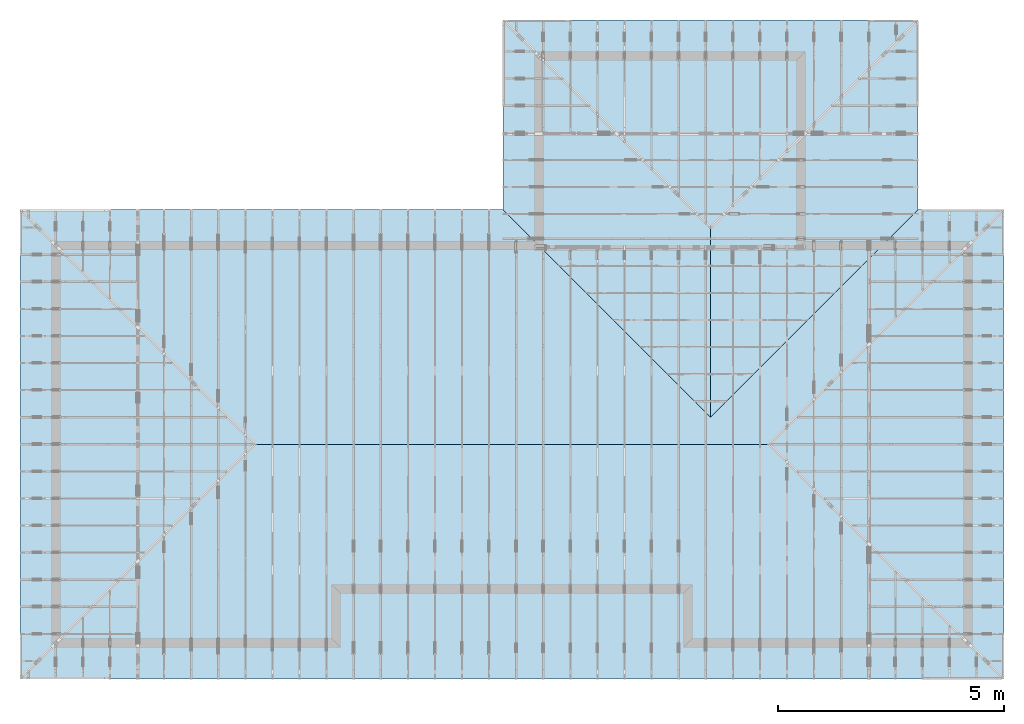
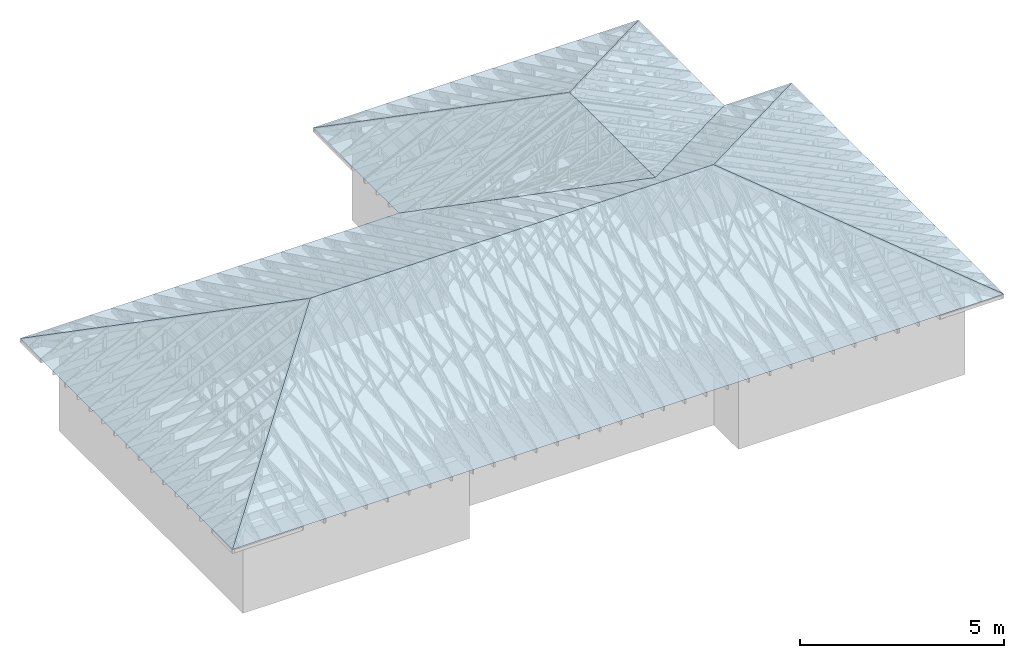
# One storey, part 54 of 159: 7 slabs.
"""IFC2X3 building model written with IfcOpenShell, lengths in millimetres."""

from ifc_helpers import new_model, si_unit, frame, origin, origin_with_axes, origin_2d, place, context, project, spatial, faceted_brep, element, save


model = new_model("IFC2X3")

# Units and contexts
model_context = context("Model", 3, precision=1e-05, world=origin())
plan_context = context("Plan", 2, precision=1e-05, world=origin_2d())
ifc_project = project(units=[si_unit("LENGTHUNIT", "METRE", prefix="MILLI"), si_unit("AREAUNIT", "SQUARE_METRE"), si_unit("VOLUMEUNIT", "CUBIC_METRE"), si_unit("SOLIDANGLEUNIT", "STERADIAN"), si_unit("PLANEANGLEUNIT", "RADIAN"), si_unit("MASSUNIT", "GRAM"), si_unit("TIMEUNIT", "SECOND"), si_unit("THERMODYNAMICTEMPERATUREUNIT", "DEGREE_CELSIUS"), si_unit("LUMINOUSINTENSITYUNIT", "LUMEN")], contexts=[model_context, plan_context])

# Site, building, storey
site_placement = place(None, origin_with_axes())
site = spatial("IfcSite", under=ifc_project, at=site_placement, CompositionType="ELEMENT")
building_placement = place(site_placement, origin_with_axes())
building = spatial("IfcBuilding", under=site, at=building_placement, Name="Plan 1", CompositionType="ELEMENT")
storey_placement = place(building_placement, origin_with_axes())
storey = spatial("IfcBuildingStorey", under=building, at=storey_placement, Name="Etasje 1", CompositionType="ELEMENT", Elevation=0.0)

# Slabs
slab_1_placement = place(storey_placement, frame((9333.339762369791, 1900.0007934570312, 1388.1045954553751), z_axis=(0.0, -0.4383711467890774, 0.898794046299167), x_axis=(1.0, 0.0, 0.0)))
element("IfcSlab", 1, at=slab_1_placement, inside=storey, Name="1", PredefinedType="ROOF", context=model_context, shape_type="Brep", body=[
    faceted_brep([(6566.673909505209, 2892.764705696325, -2.842170943040401e-14), (-4833.340250651041, 2892.764705696325, -2.842170943040401e-14), (-10033.339762369791, -2892.7647056963247, -2.842170943040401e-14), (11766.671956380209, -2892.7647056963247, -2.842170943040401e-14)], [[[0, 1, 2, 3]]]),
])
slab_2_placement = place(storey_placement, frame((19366.679036458332, 4500.0005289713545, 965.4032965709166), z_axis=(0.4383711467890774, -2.684160458451531e-17, 0.898794046299167), x_axis=(6.123031769111886e-17, 1.0, -3.0814879110195774e-33)))
element("IfcSlab", 2, at=slab_2_placement, inside=storey, Name="2", PredefinedType="ROOF", context=model_context, shape_type="Brep", body=[
    faceted_brep([(-5199.999430338542, -1928.5093058067723, 0.0), (5199.999471028646, -1928.5093058067723, 0.0), (-4.069010446983157e-05, 3857.018611613541, -1.8189894035458565e-12)], [[[0, 1, 2]]]),
])
slab_3_placement = place(storey_placement, frame((1033.333170572917, 4500.000528971354, 965.4030741306037), z_axis=(-0.4383711467890774, 8.052481375354593e-17, 0.898794046299167), x_axis=(-1.836909530733566e-16, -1.0, -1.232595164407831e-32)))
element("IfcSlab", 3, at=slab_3_placement, inside=storey, Name="4", PredefinedType="ROOF", context=model_context, shape_type="Brep", body=[
    faceted_brep([(-5199.999471028646, -1928.5098490694395, 5.684341886080801e-13), (5199.999430338541, -1928.5098490694377, -2.8421709430404007e-13), (4.0690102650842164e-05, 3857.019698138877, -2.8421709430404007e-13)], [[[0, 1, 2]]]),
])
slab_4_placement = place(storey_placement, frame((12253.342545572916, 6700.000195312499, 1583.1976704373105), z_axis=(5.368320916903062e-17, 0.4383711467890774, 0.898794046299167), x_axis=(-1.0, 1.2246063538223773e-16, -6.162975822039155e-33)))
element("IfcSlab", 4, at=slab_4_placement, inside=storey, Name="5", PredefinedType="ROOF", context=model_context, shape_type="Brep", body=[
    faceted_brep([(7753.343033854167, 2447.7239430878144, 0.0), (-3646.6711263020843, 2447.7239430878144, 0.0), (-8846.669173177084, -3337.805604120501, 0.0), (-6946.669173177084, -3337.805604120501, 0.0), (-2346.6701497395843, 1780.1633220653675, 0.0), (2253.3298502604175, -3337.805604120501, 0.0), (12953.342545572918, -3337.805604120501, 0.0)], [[[0, 1, 2, 3, 4, 5, 6]]]),
])
slab_5_placement = place(storey_placement, frame((16900.01220703125, 9499.999999999998, 1241.785176141797), z_axis=(0.4383711467890774, -2.684160458451531e-17, 0.898794046299167), x_axis=(6.123031769111886e-17, 1.0, -3.0814879110195774e-33)))
element("IfcSlab", 5, at=slab_5_placement, inside=storey, Name="6", PredefinedType="ROOF", context=model_context, shape_type="Brep", body=[
    faceted_brep([(-200.0, 2558.983919830267, 1.8189894035458563e-12), (-4399.999999999999, 2558.983919830267, 1.8189894035458563e-12), (200.00000000000182, -2558.983919830267, 1.8189894035458563e-12), (4400.000000000002, -2558.983919830267, 1.8189894035458563e-12)], [[[0, 1, 2, 3]]]),
])
slab_6_placement = place(storey_placement, frame((14600.012369791668, 12366.666666666666, 867.8566253343251), z_axis=(5.368320916903062e-17, 0.4383711467890774, 0.898794046299167), x_axis=(-1.0, 1.2246063538223773e-16, -6.162975822039155e-33)))
element("IfcSlab", 6, at=slab_6_placement, inside=storey, Name="7", PredefinedType="ROOF", context=model_context, shape_type="Brep", body=[
    faceted_brep([(-4599.999348958334, -1705.989642061957, -9.094947017729282e-13), (4599.999674479168, -1705.989642061957, -9.094947017729282e-13), (-0.00032552083212067373, 3411.9792841239123, 0.0)], [[[0, 1, 2]]]),
])
slab_7_placement = place(storey_placement, frame((12300.012695312498, 9499.999999999998, 1241.7849694118413), z_axis=(-0.4383711467890774, 8.052481375354593e-17, 0.898794046299167), x_axis=(-1.836909530733566e-16, -1.0, -1.232595164407831e-32)))
element("IfcSlab", 7, at=slab_7_placement, inside=storey, Name="8", PredefinedType="ROOF", context=model_context, shape_type="Brep", body=[
    faceted_brep([(4399.999999999997, 2558.9844630929383, -3.6350710512584224e-27), (199.99999999999818, 2558.9844630929383, -3.6350710512584224e-27), (-4400.000000000002, -2558.984463092931, -3.6350710512584224e-27), (-200.00000000000182, -2558.984463092931, -3.6350710512584224e-27)], [[[0, 1, 2, 3]]]),
])

save(model, "model.ifc")
